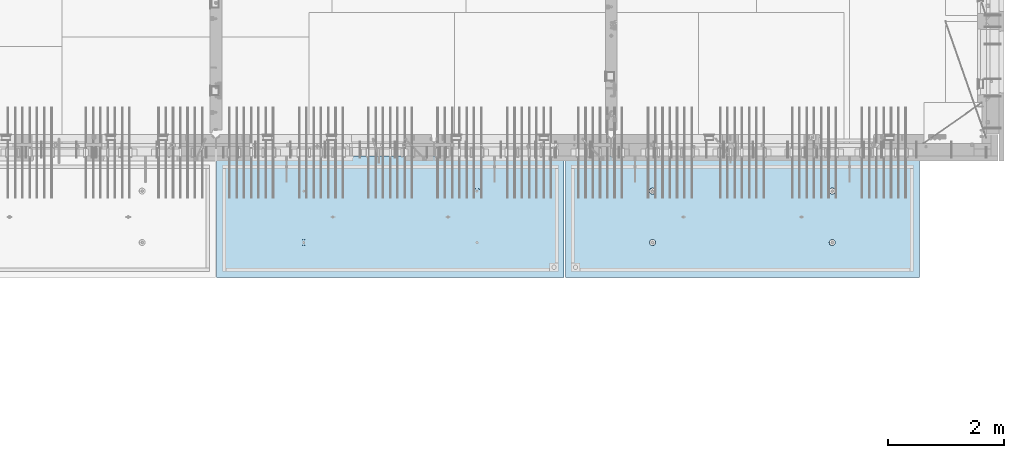
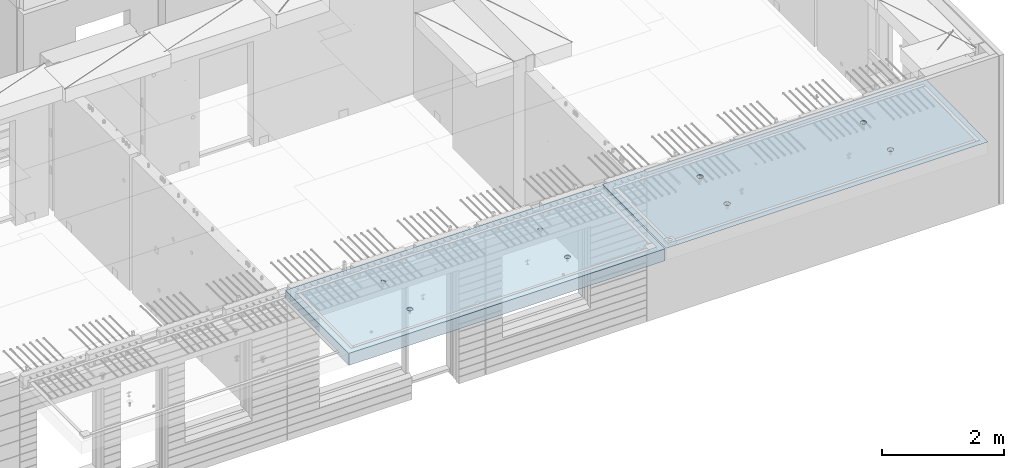
# One storey, part 196 of 341: 2 slabs, 2 elements without a shape of their own.
"""IFC2X3 building model written with IfcOpenShell, lengths in millimetres."""

from ifc_helpers import new_model, si_unit, frame, origin_with_axes, place, context, subcontext, project, spatial, faceted_brep, material, type_object, element, aggregate, save


model = new_model("IFC2X3")

# Units and contexts
model_context = context("Model", 3, precision=1e-05, world=origin_with_axes())
body_context = subcontext(model_context, "Body", "Model", "MODEL_VIEW")
ifc_project = project(units=[si_unit("LENGTHUNIT", "METRE", prefix="MILLI"), si_unit("AREAUNIT", "SQUARE_METRE"), si_unit("VOLUMEUNIT", "CUBIC_METRE"), si_unit("MASSUNIT", "GRAM", prefix="KILO"), si_unit("TIMEUNIT", "SECOND"), si_unit("PLANEANGLEUNIT", "RADIAN"), si_unit("SOLIDANGLEUNIT", "STERADIAN"), si_unit("THERMODYNAMICTEMPERATUREUNIT", "DEGREE_CELSIUS"), si_unit("LUMINOUSINTENSITYUNIT", "LUMEN")], contexts=[model_context])

# Site, building, storey
site_placement = place(None, origin_with_axes())
site = spatial("IfcSite", under=ifc_project, at=site_placement, CompositionType="ELEMENT")
building_placement = place(site_placement, origin_with_axes())
building = spatial("IfcBuilding", under=site, at=building_placement, CompositionType="ELEMENT")
storey_placement = place(building_placement, origin_with_axes())
storey = spatial("IfcBuildingStorey", under=building, at=storey_placement, Name="5", CompositionType="ELEMENT", Elevation=0.0)

# Assembly, slab
assembly_1_placement = place(storey_placement, origin_with_axes())
assembly_1 = element("IfcElementAssembly", 1, at=assembly_1_placement, inside=storey, AssemblyPlace="NOTDEFINED", PredefinedType="REINFORCEMENT_UNIT")
ifc_material = material(Name="CONCRETE/C35/45")
slab_type_1 = type_object("IfcSlabType", PredefinedType="NOTDEFINED")
slab_1_placement = place(assembly_1_placement, frame((33909.9998568133, 7629.99655735226, 96720.0), z_axis=(-1.11800000013248e-06, -0.999999999999375, 0.0), x_axis=(-0.999999999999093, 1.34699999998405e-06, 0.0)))
slab_1 = element("IfcSlab", 2, at=slab_1_placement, type_object=slab_type_1, material=ifc_material, PredefinedType="FLOOR", context=body_context, shape_type="Brep", body=[
    faceted_brep([(4540.5429407651, 4.39872694581572, 1501.06992058926), (4541.14829635528, 10.0, 1500.87322939105), (4548.44394652849, 10.0, 1515.19178906455), (4547.94177529477, 4.5376880098047, 1515.55663695519), (4559.80720044041, 10.0, 1526.55506865745), (4559.44971344555, 4.64790814399021, 1527.04710612474), (4574.1257436257, 10.0, 1533.85075119058), (4573.94028523447, 4.71864591048507, 1534.42153123348), (4589.99797731422, 10.0, 1536.36468442559), (4589.99797663917, 4.74301553473924, 1536.96206902392), (4605.87021668419, 10.0, 1533.85078706184), (4606.05567377324, 4.71864625823218, 1534.42156748629), (4620.18877635769, 10.0, 1526.55513688863), (4620.54626219634, 4.64790880566579, 1527.04717510301), (4631.55205595059, 10.0, 1515.19188297671), (4632.05422627598, 4.53768892097287, 1515.5567319414), (4638.84773848372, 10.0, 1500.87333979142), (4639.45309351355, 4.39872801757883, 1501.0700323201), (4641.36167171873, 10.0, 1485.0011061029), (4642.01569559209, 4.24458991442225, 1485.00110684195), (4638.84777435497, 10.0, 1469.12886673293), (4639.48645790269, 4.09034788147255, 1468.92134666652), (4631.55212418177, 10.0, 1454.81030705943), (4632.10822132771, 3.95111487063696, 1454.40627979329), (4620.18887026985, 10.0, 1443.44702746653), (4620.60028327593, 3.84055859092041, 1442.88076738872), (4605.87032708456, 10.0, 1436.1513449334), (4606.0891136727, 3.76954887632746, 1435.47799164192), (4589.99809339604, 10.0, 1433.63741169839), (4589.99809419923, 3.74507537655882, 1432.92662480936), (4574.12585402606, 10.0, 1436.15130906214), (4573.90706894744, 3.76954852712515, 1435.47795523847), (4559.80729435257, 10.0, 1443.44695923535), (4559.39588258188, 3.84055792690197, 1442.8806981667), (4548.44401475967, 10.0, 1454.81021314727), (4547.88791844284, 3.95111395715503, 1454.40618456334), (4541.14833222653, 10.0, 1469.12875633256), (4540.50964903182, 4.09034680826881, 1468.92123478504), (4538.63439899152, 10.0, 1485.00099002108), (4537.98037499001, 4.24458878673613, 1485.00098928203), (0.0, 10.0, 0.0), (0.0, -10.0, 0.0), (0.000819232023786753, 10.0, 2085.00366210937), (6090.0, 10.0, 1.39971234602854e-09), (6090.0, -10.0, 1.39971234602854e-09), (6090.0009765625, 10.0, 2085.00366210937), (1450.13343574908, -4.39996016312216, 583.805178487186), (1451.68970517172, 10.0, 584.310843019489), (1449.20358093267, 10.0, 600.007498901724), (1447.58488291994, -4.2445425120095, 600.007497072595), (1457.56794425657, -4.54025428339082, 569.17949076172), (1458.90468325205, 10.0, 570.15069079864), (1469.16362510388, -4.65165300057561, 557.566154097598), (1470.14226284945, 10.0, 558.913136598135), (1483.78541952188, -4.72320365252381, 550.106985529351), (1484.30243137612, 10.0, 551.698190519764), (1499.99909477071, -4.74786334385863, 547.536208193364), (1499.99909287695, 10.0, 549.212101755165), (1516.2127641972, -4.72320330067305, 550.107022210277), (1515.69574875919, 10.0, 551.698225994214), (1530.8345417251, -4.65165233150765, 557.566223847243), (1529.85590098004, 10.0, 558.913204074546), (1542.4301962863, -4.54025336292398, 569.179586717545), (1541.09345518054, 10.0, 570.150783671952), (1549.86467170747, -4.39995908172568, 583.805291221456), (1548.30840125891, 10.0, 584.310952198615), (1552.41318790712, -4.24454137573775, 600.00761552858), (1550.79449002351, 10.0, 600.007613699451), (1549.83105300624, -4.08922839167644, 616.199022553535), (1548.30836578447, 10.0, 615.704269581685), (1542.37578967018, -3.94920829200419, 630.796143582923), (1541.09338770413, 10.0, 629.864421802535), (1530.78010888273, -3.83814828256436, 642.374169903326), (1529.85580810672, 10.0, 641.101976003039), (1516.17906941009, -3.76687165064504, 649.804771831361), (1515.69563958006, 10.0, 648.316922081409), (1499.99897631459, -3.74231662515376, 652.364637735232), (1499.99897807923, 10.0, 650.803010846011), (1483.81888899212, -3.76687200104061, 649.804735302227), (1484.30232219699, 10.0, 648.316886606961), (1469.21786628045, -3.83814894927491, 642.374100399286), (1470.14216997614, 10.0, 641.101908526629), (1457.62221161949, -3.94920921009907, 630.796047872702), (1458.90461577564, 10.0, 629.864328929222), (1450.16698124064, -4.08922947161773, 616.198909971055), (1451.68966969727, 10.0, 615.704160402559), (1450.509655854, 4.09040925785666, 1468.92774521603), (1451.1483322995, 10.0, 1469.13526457059), (1448.63439906449, 10.0, 1485.00749825911), (1447.98038215714, 4.24465121529647, 1485.00749752007), (1457.88792425878, 3.95117642574769, 1454.41269697389), (1458.44401483263, 10.0, 1454.8167213853), (1469.39588682837, 3.84062041057041, 1442.8872121491), (1469.80729442553, 10.0, 1443.45346747338), (1483.90707121489, 3.76961102048517, 1435.48447023045), (1484.12585409903, 10.0, 1436.15781730018), (1499.99809427218, 3.74513787325122, 1432.93314014929), (1499.998093469, 10.0, 1433.64391993642), (1516.08911155117, 3.76961136968748, 1435.48450663389), (1515.87032715752, 10.0, 1436.15785317143), (1530.60027917537, 3.8406210745743, 1442.88728137111), (1530.18887034281, 10.0, 1443.45353570456), (1542.1082156577, 3.95117733922962, 1454.41279220383), (1541.55212425473, 10.0, 1454.81681529746), (1549.48645122644, 4.09041033107496, 1468.92785709749), (1548.84777442794, 10.0, 1469.13537497096), (1552.0156885709, 4.24465234298259, 1485.00761507997), (1551.3616717917, 10.0, 1485.00761434093), (1549.45308684185, 4.39879042512621, 1501.07653836665), (1548.84773855669, 10.0, 1500.87984802946), (1542.05422061333, 4.5377513095591, 1515.56323601226), (1541.55205602355, 10.0, 1515.19839121474), (1530.54625810314, 4.64797117923445, 1527.0536776068), (1530.18877643065, 10.0, 1526.56164512666), (1516.05567165627, 4.71870862215292, 1534.42806898436), (1515.87021675715, 10.0, 1533.85729529987), (1499.99797671215, 4.74307789534214, 1536.96857017552), (1499.99797738718, 10.0, 1536.37119266363), (1483.94028749739, 4.71870827439125, 1534.42803273156), (1484.12574369866, 10.0, 1533.85725942862), (1469.44971768469, 4.64797051755886, 1527.05360862854), (1469.80720051337, 10.0, 1526.56157689548), (1457.94178110336, 4.53775039840548, 1515.56314102606), (1458.44394660145, 10.0, 1515.19829730258), (1450.54294758273, 4.39878935334855, 1501.07642663582), (1451.14829642825, 10.0, 1500.87973762909), (4619.85580803376, 10.0, 641.095467765007), (4620.78011297592, -3.83821065611846, 642.367667399533), (4606.17907152706, -3.76693401455123, 649.798270333285), (4605.6956395071, 10.0, 648.310413843377), (4631.09338763116, 10.0, 629.857913564502), (4632.37579533283, -3.94927068060497, 630.789639512066), (4638.30836571149, 10.0, 615.697761343654), (4639.83105967794, -4.08929079922382, 616.192516506986), (4640.79448995054, 10.0, 600.001105461418), (4642.4131949283, -4.24460380429809, 600.001107290555), (4638.30840118594, 10.0, 584.304443960583), (4639.86467838373, -4.40002153132809, 583.798780790478), (4631.09345510758, 10.0, 570.14427543392), (4632.43020195632, -4.54031583151664, 569.173074307006), (4619.85590090707, 10.0, 558.906695836514), (4620.83454582566, -4.65171481517609, 557.559709864858), (4605.69574868622, 10.0, 551.691717756181), (4606.21276631872, -4.72326579401852, 550.100507218302), (4589.99909280399, 10.0, 549.205593517132), (4589.99909469776, -4.74792584055103, 547.529692853434), (4574.30243130315, 10.0, 551.691682281732), (4573.78541725442, -4.72326614588383, 550.10047053737), (4560.14226277649, 10.0, 558.906628360102), (4559.16362085739, -4.65171548424405, 557.559640115202), (4548.90468317908, 10.0, 570.144182560607), (4547.56793844064, -4.54031675198348, 569.172978351166), (4541.68970509875, 10.0, 584.304334781456), (4540.1334289269, -4.40002261272457, 583.798668056191), (4547.6222058109, -3.9492715986853, 630.789543801832), (4559.21786204131, -3.83821132282901, 642.367597895483), (4573.8188867292, -3.76693436496134, 649.798233804147), (4589.99897624161, -3.74237898574211, 652.358136583629), (4537.58487575281, -4.2446049405844, 600.000988834554), (4540.166974423, -4.0892918791651, 616.192403924491), (4589.99897800626, 10.0, 650.796502607977), (4574.30232212402, 10.0, 648.310378368928), (4560.14216990317, 10.0, 641.095400288596), (4548.90461570267, 10.0, 629.85782069119), (4541.6896696243, 10.0, 615.697652164527), (4539.2035808597, 10.0, 600.000990663691)], [[[0, 1, 2, 3]], [[3, 2, 4, 5]], [[5, 4, 6, 7]], [[8, 9, 7, 6]], [[10, 11, 9, 8]], [[12, 13, 11, 10]], [[14, 15, 13, 12]], [[16, 17, 15, 14]], [[18, 19, 17, 16]], [[20, 21, 19, 18]], [[22, 23, 21, 20]], [[24, 25, 23, 22]], [[25, 24, 26, 27]], [[27, 26, 28, 29]], [[29, 28, 30, 31]], [[31, 30, 32, 33]], [[33, 32, 34, 35]], [[35, 34, 36, 37]], [[37, 36, 38, 39]], [[39, 38, 1, 0]], [[40, 41, 42]], [[40, 43, 44, 41]], [[43, 45, 44]], [[46, 47, 48, 49]], [[50, 51, 47, 46]], [[52, 53, 51, 50]], [[54, 55, 53, 52]], [[56, 57, 55, 54]], [[58, 59, 57, 56]], [[59, 58, 60, 61]], [[61, 60, 62, 63]], [[63, 62, 64, 65]], [[65, 64, 66, 67]], [[67, 66, 68, 69]], [[69, 68, 70, 71]], [[71, 70, 72, 73]], [[73, 72, 74, 75]], [[75, 74, 76, 77]], [[78, 79, 77, 76]], [[80, 81, 79, 78]], [[82, 83, 81, 80]], [[84, 85, 83, 82]], [[49, 48, 85, 84]], [[86, 87, 88, 89]], [[90, 91, 87, 86]], [[92, 93, 91, 90]], [[94, 95, 93, 92]], [[96, 97, 95, 94]], [[98, 99, 97, 96]], [[100, 101, 99, 98]], [[101, 100, 102, 103]], [[103, 102, 104, 105]], [[105, 104, 106, 107]], [[107, 106, 108, 109]], [[109, 108, 110, 111]], [[111, 110, 112, 113]], [[113, 112, 114, 115]], [[115, 114, 116, 117]], [[117, 116, 118, 119]], [[120, 121, 119, 118]], [[122, 123, 121, 120]], [[124, 125, 123, 122]], [[89, 88, 125, 124]], [[126, 127, 128, 129]], [[130, 131, 127, 126]], [[132, 133, 131, 130]], [[134, 135, 133, 132]], [[136, 137, 135, 134]], [[138, 139, 137, 136]], [[140, 141, 139, 138]], [[142, 143, 141, 140]], [[143, 142, 144, 145]], [[145, 144, 146, 147]], [[147, 146, 148, 149]], [[149, 148, 150, 151]], [[151, 150, 152, 153]], [[41, 44, 45, 42], [3, 5, 7, 9, 11, 13, 15, 17, 19, 21, 23, 25, 27, 29, 31, 33, 35, 37, 39, 0], [154, 155, 156, 157, 128, 127, 131, 133, 135, 137, 139, 141, 143, 145, 147, 149, 151, 153, 158, 159], [122, 120, 118, 116, 114, 112, 110, 108, 106, 104, 102, 100, 98, 96, 94, 92, 90, 86, 89, 124], [82, 80, 78, 76, 74, 72, 70, 68, 66, 64, 62, 60, 58, 56, 54, 52, 50, 46, 49, 84]], [[129, 128, 157, 160]], [[156, 161, 160, 157]], [[155, 162, 161, 156]], [[154, 163, 162, 155]], [[159, 164, 163, 154]], [[158, 165, 164, 159]], [[153, 152, 165, 158]], [[43, 40, 42, 45], [34, 32, 30, 28, 26, 24, 22, 20, 18, 16, 14, 12, 10, 8, 6, 4, 2, 1, 38, 36], [150, 148, 146, 144, 142, 140, 138, 136, 134, 132, 130, 126, 129, 160, 161, 162, 163, 164, 165, 152], [91, 93, 95, 97, 99, 101, 103, 105, 107, 109, 111, 113, 115, 117, 119, 121, 123, 125, 88, 87], [51, 53, 55, 57, 59, 61, 63, 65, 67, 69, 71, 73, 75, 77, 79, 81, 83, 85, 48, 47]]]),
])
aggregate(assembly_1, [slab_1])

assembly_2_placement = place(storey_placement, origin_with_axes())
assembly_2 = element("IfcElementAssembly", 3, at=assembly_2_placement, inside=storey, AssemblyPlace="NOTDEFINED", PredefinedType="REINFORCEMENT_UNIT")
slab_type_2 = type_object("IfcSlabType", PredefinedType="NOTDEFINED")
slab_2_placement = place(assembly_2_placement, frame((27799.9998568133, 7629.99655735226, 96590.0), z_axis=(-1.11800000013248e-06, -0.999999999999375, 0.0), x_axis=(-0.999999999999093, 1.34699999998405e-06, 0.0)))
slab_2 = element("IfcSlab", 4, at=slab_2_placement, type_object=slab_type_2, material=ifc_material, PredefinedType="FLOOR", context=body_context, shape_type="Brep", body=[
    faceted_brep([(4464.54840508898, -115.0, 647.555217913627), (4450.61000036748, -115.0, 640.453225774507), (4439.54842599525, -115.0, 629.391625938503), (4432.44646594236, -115.0, 615.453204868262), (4429.99930954105, -115.0, 600.002352332828), (4432.44650151022, -115.0, 584.551505430789), (4439.54849364933, -115.0, 570.613100709295), (4450.61009348534, -115.0, 559.551526337066), (4464.54851455558, -115.0, 552.449566284174), (4479.99936709102, -115.0, 550.002409882861), (4495.45021399306, -115.0, 552.449601852029), (4509.38861871455, -115.0, 559.551593991148), (4520.45019308678, -115.0, 570.613193827152), (4527.55215313967, -115.0, 584.551614897394), (4529.99930954098, -115.0, 600.002467432828), (4527.55211757181, -115.0, 615.453314334867), (4520.4501254327, -115.0, 629.39171905636), (4509.38852559669, -115.0, 640.453293428589), (4495.45010452645, -115.0, 647.555253481482), (4479.99925199102, -115.0, 650.002409882794), (4439.08882528693, -120.0, 570.279131286869), (4431.90612869169, -120.0, 584.375926971106), (4450.27612512107, -120.0, 559.091857205865), (4464.37293733984, -120.0, 551.909193061462), (4479.99936774499, -120.0, 549.43422806468), (4495.62579245274, -120.0, 551.909229033498), (4509.72258813697, -120.0, 559.091925628744), (4520.90986221798, -120.0, 570.279225462882), (4528.09252636238, -120.0, 584.37603768165), (4530.56749135916, -120.0, 600.002468086805), (4528.09249039035, -120.0, 615.628892794549), (4520.9097937951, -120.0, 629.725688478787), (4509.72249396096, -120.0, 640.912962559792), (4495.6256817422, -120.0, 648.095626704194), (4479.99925133704, -120.0, 650.570591700976), (4464.3728266293, -120.0, 648.095590732158), (4450.27603094506, -120.0, 640.912894136913), (4439.08875686405, -120.0, 629.725594302773), (4431.90609271965, -120.0, 615.628782084005), (4429.43112772287, -120.0, 600.002351678851), (0.000819232023786753, -120.0, 2085.00366210938), (5980.0009765625, -120.0, 2085.00366210937), (5980.0009765625, 120.0, 2085.00366210937), (0.000819232023786753, 120.0, 2085.00366210938), (5980.0, -120.0, -2.4019755073823e-09), (5980.0, 120.0, -2.4019755073823e-09), (-7.27595761418343e-12, -120.0, -9.09494701772928e-13), (-7.27595761418343e-12, 120.0, -9.09494701772928e-13), (1515.44890870648, -105.0, 1437.44477976918), (1529.38731342797, -105.0, 1444.5467719083), (1540.4488878002, -105.0, 1455.60837174431), (1547.55084785309, -105.0, 1469.54679281455), (1549.99800425441, -105.0, 1484.99764534998), (1547.55081228524, -105.0, 1500.44849225202), (1540.44882014612, -105.0, 1514.38689697351), (1529.38722031012, -105.0, 1525.44847134574), (1515.44879923988, -105.0, 1532.55043139864), (1499.99794670444, -105.0, 1534.99758779995), (1484.5470998024, -105.0, 1532.55039583078), (1470.60869508091, -105.0, 1525.44840369166), (1459.54712070868, -105.0, 1514.38680385566), (1452.44516065579, -105.0, 1500.44838278542), (1449.99800425447, -105.0, 1484.99753024998), (1452.44519622364, -105.0, 1469.54668334794), (1459.54718836276, -105.0, 1455.60827862645), (1470.60878819877, -105.0, 1444.54670425422), (1484.547209269, -105.0, 1437.44474420133), (1499.99806180444, -105.0, 1434.99758780001), (1450.82407776805, -120.0, 1469.01994796889), (1448.29345879993, -120.0, 1484.99752828805), (1458.16818327555, -120.0, 1454.60637035917), (1469.60688310596, -120.0, 1443.16769686061), (1484.02047762178, -120.0, 1435.82362453319), (1499.99806376637, -120.0, 1433.29304234547), (1515.97564408552, -120.0, 1435.82366131359), (1530.38922169525, -120.0, 1443.16776682109), (1541.82789519381, -120.0, 1454.6064666515), (1549.17196752123, -120.0, 1469.02006116732), (1551.70254970895, -120.0, 1484.99764731191), (1549.17193074083, -120.0, 1500.97522763107), (1541.82782523334, -120.0, 1515.38880524079), (1530.38912540293, -120.0, 1526.82747873935), (1515.9755308871, -120.0, 1534.17155106677), (1499.99794474251, -120.0, 1536.70213325449), (1484.02036442336, -120.0, 1534.17151428637), (1469.60678681363, -120.0, 1526.82740877888), (1458.16811331507, -120.0, 1515.38870894846), (1450.82404098765, -120.0, 1500.97511443265), (1484.54840517324, -115.0, 647.55178787166), (1470.61000045175, -115.0, 640.44979573254), (1459.54842607952, -115.0, 629.388195896537), (1452.44646602663, -115.0, 615.449774826296), (1449.99930962532, -115.0, 599.998922290862), (1452.44650159449, -115.0, 584.548075388822), (1459.5484937336, -115.0, 570.609670667329), (1470.61009356961, -115.0, 559.5480962951), (1484.54851463985, -115.0, 552.446136242207), (1499.99936717528, -115.0, 549.998979840894), (1515.45021407733, -115.0, 552.446171810063), (1529.38861879882, -115.0, 559.548163949182), (1540.45019317105, -115.0, 570.609763785185), (1547.55215322394, -115.0, 584.548184855427), (1549.99930962525, -115.0, 599.999037390861), (1547.55211765608, -115.0, 615.449884292901), (1540.45012551697, -115.0, 629.388289014393), (1529.38852568096, -115.0, 640.449863386622), (1515.45010461072, -115.0, 647.551823439516), (1499.99925207528, -115.0, 649.998979840828), (1451.90612877595, -120.0, 584.37249692914), (1449.43112780714, -120.0, 599.998921636884), (1459.0888253712, -120.0, 570.275701244902), (1470.27612520534, -120.0, 559.088427163899), (1484.3729374241, -120.0, 551.905763019496), (1499.99936782926, -120.0, 549.430798022713), (1515.62579253701, -120.0, 551.905798991532), (1529.72258822124, -120.0, 559.088495586778), (1540.90986230225, -120.0, 570.275795420916), (1548.09252644665, -120.0, 584.372607639683), (1550.56749144343, -120.0, 599.999038044839), (1548.09249047462, -120.0, 615.625462752582), (1540.90979387937, -120.0, 629.72225843682), (1529.72249404523, -120.0, 640.909532517825), (1515.62568182647, -120.0, 648.092196662227), (1499.9992514213, -120.0, 650.56716165901), (1484.37282671356, -120.0, 648.092160690191), (1470.27603102933, -120.0, 640.909464094946), (1459.08875694832, -120.0, 629.722164260806), (1451.90609280392, -120.0, 615.625352042039), (4495.44890862221, -105.0, 1437.44820981115), (4509.3873133437, -105.0, 1444.55020195027), (4520.44888771593, -105.0, 1455.61180178627), (4527.55084776882, -105.0, 1469.55022285651), (4529.99800417014, -105.0, 1485.00107539195), (4527.55081220097, -105.0, 1500.45192229399), (4520.44882006185, -105.0, 1514.39032701548), (4509.38722022585, -105.0, 1525.45190138771), (4495.44879915561, -105.0, 1532.5538614406), (4479.99794662017, -105.0, 1535.00101784192), (4464.54709971813, -105.0, 1532.55382587275), (4450.60869499664, -105.0, 1525.45183373363), (4439.54712062441, -105.0, 1514.39023389763), (4432.44516057152, -105.0, 1500.45181282738), (4429.9980041702, -105.0, 1485.00096029195), (4432.44519613937, -105.0, 1469.55011338991), (4439.54718827849, -105.0, 1455.61170866842), (4450.6087881145, -105.0, 1444.55013429619), (4464.54720918474, -105.0, 1437.44817424329), (4479.99806172017, -105.0, 1435.00101784198), (4430.82407768378, -120.0, 1469.02337801086), (4428.29345871566, -120.0, 1485.00095833002), (4438.16818319128, -120.0, 1454.60980040114), (4449.60688302169, -120.0, 1443.17112690258), (4464.02047753751, -120.0, 1435.82705457516), (4479.99806368211, -120.0, 1433.29647238744), (4495.97564400126, -120.0, 1435.82709135556), (4510.38922161098, -120.0, 1443.17119686305), (4521.82789510954, -120.0, 1454.60989669347), (4529.17196743696, -120.0, 1469.02349120928), (4531.70254962468, -120.0, 1485.00107735388), (4529.17193065656, -120.0, 1500.97865767303), (4521.82782514907, -120.0, 1515.39223528276), (4510.38912531866, -120.0, 1526.83090878132), (4495.97553080284, -120.0, 1534.17498110874), (4479.99794465824, -120.0, 1536.70556329646), (4464.02036433909, -120.0, 1534.17494432834), (4449.60678672936, -120.0, 1526.83083882084), (4438.1681132308, -120.0, 1515.39213899043), (4430.82404090338, -120.0, 1500.97854447461)], [[[0, 1, 2, 3, 4, 5, 6, 7, 8, 9, 10, 11, 12, 13, 14, 15, 16, 17, 18, 19]], [[20, 6, 5, 21]], [[22, 7, 6, 20]], [[23, 8, 7, 22]], [[24, 9, 8, 23]], [[25, 10, 9, 24]], [[26, 11, 10, 25]], [[27, 12, 11, 26]], [[28, 13, 12, 27]], [[29, 14, 13, 28]], [[30, 15, 14, 29]], [[31, 16, 15, 30]], [[32, 17, 16, 31]], [[33, 18, 17, 32]], [[34, 19, 18, 33]], [[35, 0, 19, 34]], [[36, 1, 0, 35]], [[37, 2, 1, 36]], [[38, 3, 2, 37]], [[39, 4, 3, 38]], [[21, 5, 4, 39]], [[40, 41, 42, 43]], [[41, 44, 45, 42]], [[44, 46, 47, 45]], [[42, 45, 47, 43]], [[46, 40, 43, 47]], [[48, 49, 50, 51, 52, 53, 54, 55, 56, 57, 58, 59, 60, 61, 62, 63, 64, 65, 66, 67]], [[68, 63, 62, 69]], [[70, 64, 63, 68]], [[71, 65, 64, 70]], [[72, 66, 65, 71]], [[73, 67, 66, 72]], [[74, 48, 67, 73]], [[75, 49, 48, 74]], [[76, 50, 49, 75]], [[77, 51, 50, 76]], [[78, 52, 51, 77]], [[79, 53, 52, 78]], [[80, 54, 53, 79]], [[81, 55, 54, 80]], [[82, 56, 55, 81]], [[83, 57, 56, 82]], [[84, 58, 57, 83]], [[85, 59, 58, 84]], [[86, 60, 59, 85]], [[87, 61, 60, 86]], [[69, 62, 61, 87]], [[88, 89, 90, 91, 92, 93, 94, 95, 96, 97, 98, 99, 100, 101, 102, 103, 104, 105, 106, 107]], [[108, 93, 92, 109]], [[110, 94, 93, 108]], [[111, 95, 94, 110]], [[112, 96, 95, 111]], [[113, 97, 96, 112]], [[114, 98, 97, 113]], [[115, 99, 98, 114]], [[116, 100, 99, 115]], [[117, 101, 100, 116]], [[118, 102, 101, 117]], [[119, 103, 102, 118]], [[120, 104, 103, 119]], [[121, 105, 104, 120]], [[122, 106, 105, 121]], [[123, 107, 106, 122]], [[124, 88, 107, 123]], [[125, 89, 88, 124]], [[126, 90, 89, 125]], [[127, 91, 90, 126]], [[109, 92, 91, 127]], [[128, 129, 130, 131, 132, 133, 134, 135, 136, 137, 138, 139, 140, 141, 142, 143, 144, 145, 146, 147]], [[148, 143, 142, 149]], [[150, 144, 143, 148]], [[151, 145, 144, 150]], [[152, 146, 145, 151]], [[153, 147, 146, 152]], [[154, 128, 147, 153]], [[155, 129, 128, 154]], [[156, 130, 129, 155]], [[157, 131, 130, 156]], [[158, 132, 131, 157]], [[159, 133, 132, 158]], [[160, 134, 133, 159]], [[161, 135, 134, 160]], [[162, 136, 135, 161]], [[163, 137, 136, 162]], [[164, 138, 137, 163]], [[165, 139, 138, 164]], [[166, 140, 139, 165]], [[167, 141, 140, 166]], [[149, 142, 141, 167]], [[44, 41, 40, 46], [37, 36, 35, 34, 33, 32, 31, 30, 29, 28, 27, 26, 25, 24, 23, 22, 20, 21, 39, 38], [166, 165, 164, 163, 162, 161, 160, 159, 158, 157, 156, 155, 154, 153, 152, 151, 150, 148, 149, 167], [126, 125, 124, 123, 122, 121, 120, 119, 118, 117, 116, 115, 114, 113, 112, 111, 110, 108, 109, 127], [86, 85, 84, 83, 82, 81, 80, 79, 78, 77, 76, 75, 74, 73, 72, 71, 70, 68, 69, 87]]]),
])
aggregate(assembly_2, [slab_2])

save(model, "model.ifc")
